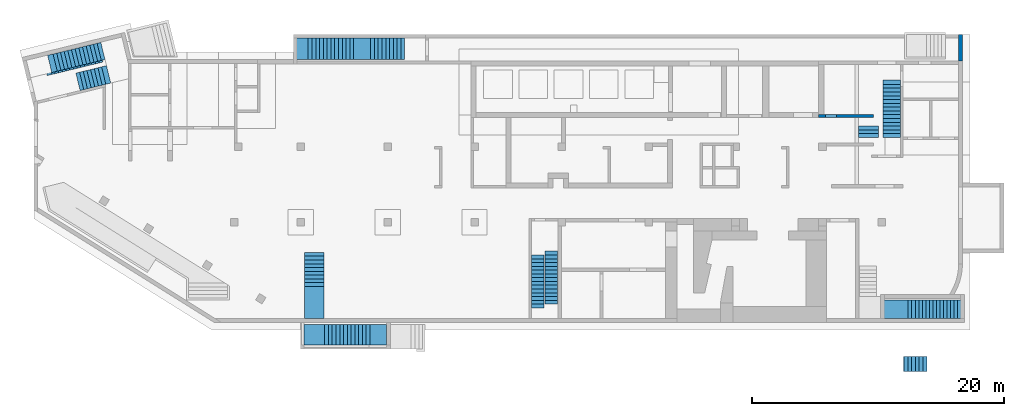
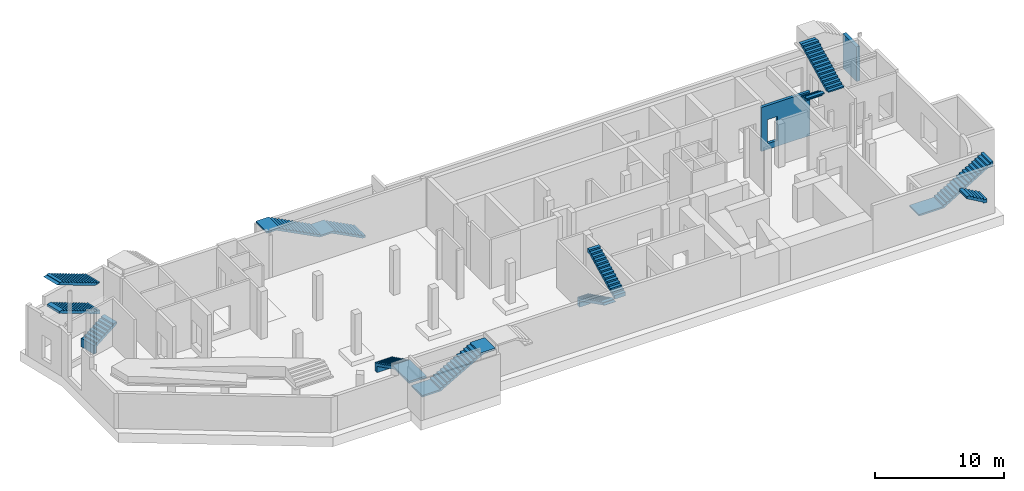
# One storey, part 4 of 9: 11 stairs, 2 walls, 2 openings.
"""IFC4 building model written with IfcOpenShell, lengths in millimetres."""

from ifc_helpers import new_model, entity, si_unit, converted_unit, derived_unit, direction, frame, origin, place, context, subcontext, project, spatial, indexed_curve, outline, extrude, polygons, material, type_object, element, save


model = new_model("IFC4")

# Units and contexts
model_context = context("Model", 3, precision=0.01, world=origin(), true_north=direction((6.12303176911189e-17, 1.0)))
plan_context = context("Plan", 3, precision=0.01, world=origin(), true_north=direction((6.12303176911189e-17, 1.0)))
body_context = subcontext(model_context, "Body", "Model", "MODEL_VIEW")
ifc_project = project(units=[si_unit("LENGTHUNIT", "METRE", prefix="MILLI"), si_unit("AREAUNIT", "SQUARE_METRE"), si_unit("VOLUMEUNIT", "CUBIC_METRE"), converted_unit("PLANEANGLEUNIT", "DEGREE", entity("IfcRatioMeasure", 0.0174532925199433), si_unit("PLANEANGLEUNIT", "RADIAN"), dimensions=[0, 0, 0, 0, 0, 0, 0]), si_unit("MASSUNIT", "GRAM", prefix="KILO"), derived_unit("MASSDENSITYUNIT", [(si_unit("MASSUNIT", "GRAM", prefix="KILO"), 1), (si_unit("LENGTHUNIT", "METRE"), -3)]), derived_unit("MOMENTOFINERTIAUNIT", [(si_unit("LENGTHUNIT", "METRE"), 4)]), si_unit("TIMEUNIT", "SECOND"), si_unit("FREQUENCYUNIT", "HERTZ"), si_unit("THERMODYNAMICTEMPERATUREUNIT", "DEGREE_CELSIUS"), derived_unit("THERMALTRANSMITTANCEUNIT", [(si_unit("MASSUNIT", "GRAM", prefix="KILO"), 1), (si_unit("THERMODYNAMICTEMPERATUREUNIT", "KELVIN"), -1), (si_unit("TIMEUNIT", "SECOND"), -3)]), derived_unit("VOLUMETRICFLOWRATEUNIT", [(si_unit("LENGTHUNIT", "METRE"), 3), (si_unit("TIMEUNIT", "SECOND"), -1)]), derived_unit("MASSFLOWRATEUNIT", [(si_unit("MASSUNIT", "GRAM", prefix="KILO"), 1), (si_unit("TIMEUNIT", "SECOND"), -1)]), derived_unit("ROTATIONALFREQUENCYUNIT", [(si_unit("TIMEUNIT", "SECOND"), -1)]), si_unit("ELECTRICCURRENTUNIT", "AMPERE"), si_unit("ELECTRICVOLTAGEUNIT", "VOLT"), si_unit("POWERUNIT", "WATT"), si_unit("FORCEUNIT", "NEWTON", prefix="KILO"), si_unit("ILLUMINANCEUNIT", "LUX"), si_unit("LUMINOUSFLUXUNIT", "LUMEN"), si_unit("LUMINOUSINTENSITYUNIT", "CANDELA"), derived_unit("USERDEFINED", [(si_unit("MASSUNIT", "GRAM", prefix="KILO"), -1), (si_unit("LENGTHUNIT", "METRE"), -2), (si_unit("TIMEUNIT", "SECOND"), 3), (si_unit("LUMINOUSFLUXUNIT", "LUMEN"), 1)]), derived_unit("LINEARVELOCITYUNIT", [(si_unit("LENGTHUNIT", "METRE"), 1), (si_unit("TIMEUNIT", "SECOND"), -1)]), si_unit("PRESSUREUNIT", "PASCAL"), derived_unit("USERDEFINED", [(si_unit("LENGTHUNIT", "METRE"), -2), (si_unit("MASSUNIT", "GRAM", prefix="KILO"), 1), (si_unit("TIMEUNIT", "SECOND"), -2)]), derived_unit("LINEARFORCEUNIT", [(si_unit("MASSUNIT", "GRAM", prefix="KILO"), 1), (si_unit("LENGTHUNIT", "METRE"), 1), (si_unit("TIMEUNIT", "SECOND"), -2), (si_unit("LENGTHUNIT", "METRE"), -1)]), derived_unit("PLANARFORCEUNIT", [(si_unit("MASSUNIT", "GRAM", prefix="KILO"), 1), (si_unit("LENGTHUNIT", "METRE"), 1), (si_unit("TIMEUNIT", "SECOND"), -2), (si_unit("LENGTHUNIT", "METRE"), -2)])], contexts=[model_context, plan_context])

# Site, building, storey
site_placement = place(None, origin())
site = spatial("IfcSite", under=ifc_project, at=site_placement, CompositionType="ELEMENT")
building_placement = place(site_placement, origin())
building = spatial("IfcBuilding", under=site, at=building_placement, CompositionType="ELEMENT")
storey_placement = place(building_placement, frame((0.0, 0.0, -4900.0)))
storey = spatial("IfcBuildingStorey", under=building, at=storey_placement, CompositionType="ELEMENT", Elevation=-4900.0)

# Wall, opening
ifc_material_1 = material()
wall_type_1 = type_object("IfcWallType", Name=":ADSK_ 25_300", PredefinedType="STANDARD")
wall_1_placement = place(storey_placement, frame((73520.0, 20500.0, 0.0), z_axis=(0.0, 0.0, 1.0), x_axis=(0.0, 1.0, 0.0)))
wall_1 = element("IfcWall", 1, at=wall_1_placement, inside=storey, type_object=wall_type_1, material=ifc_material_1, Name=":ADSK_ 25_300", ObjectType=":ADSK_ 25_300", PredefinedType="NOTDEFINED", context=body_context, shape_type="Tessellation", body=[
    polygons([(0.0, -150.000000000004, 0.0), (2100.0, -149.999999999999, 0.0), (2100.0, -149.999999999999, 3300.0), (0.000426244457389657, -150.000000000004, 3300.0), (0.0, 149.999999999997, 0.0), (0.0, 149.999999999997, 3300.0), (1800.0, 150.000000000002, 3300.0), (2100.00042624446, 150.000000000002, 3300.0), (2100.0, 150.000000000002, 0.0), (1800.0, 150.000000000002, 0.0)], [[[1, 2, 3, 4]], [[5, 6, 7, 8, 9, 10]], [[2, 1, 5, 10, 9]], [[3, 2, 9, 8]], [[4, 3, 8, 7, 6]], [[1, 4, 6, 5]]], closed=True),
])
opening_1_placement = place(wall_1_placement, origin())
element("IfcOpeningElement", 2, at=opening_1_placement, cuts=wall_1, Name=":ADSK_ 25_300", PredefinedType="OPENING", context=body_context, shape_type="SweptSolid", body=[
    extrude(outline(indexed_curve([(-1250.0, -1249.99999999902), (1250.0, -1249.99999999902), (1250.0, 1249.99999999902), (-1250.0, 1249.99999999902), (-1250.0, -1249.99999999902)], self_intersect=False)), frame((-11250.0, -250.0, 1950.0), z_axis=(0.0, 1.0, 0.0), x_axis=(1.0, 0.0, 0.0)), (0.0, 0.0, 1.0), 500.000000001948),
])

wall_type_2 = type_object("IfcWallType", Name=":ADSK_ 25_250", PredefinedType="STANDARD")
wall_2_placement = place(storey_placement, frame((66630.0, 16125.0, 0.0), z_axis=(0.0, 0.0, 1.0), x_axis=(-1.0, 0.0, 0.0)))
wall_2 = element("IfcWall", 3, at=wall_2_placement, inside=storey, type_object=wall_type_2, material=ifc_material_1, Name=":ADSK_ 25_250", ObjectType=":ADSK_ 25_250", PredefinedType="NOTDEFINED", context=body_context, shape_type="Tessellation", body=[
    polygons([(3.67825270252959e-12, -125.0, 0.0), (3960.0, -125.0, 0.0), (4359.99999999999, -125.0, 0.0), (4359.99999999999, -125.0, 4170.0), (3960.0, -125.0, 4170.0), (1500.00000000001, -125.0, 4170.0), (1200.00000000001, -125.0, 4170.0), (3.67825270252959e-12, -125.0, 4170.0), (2929.99999999999, -125.0, 2829.99999999805), (3809.99999999998, -125.000000000002, 2829.99999999804), (3809.99999999998, -125.000000000002, 550.0), (2929.99999999999, -125.0, 550.0), (4359.99999999999, 125.000000000002, 0.0), (2.95528439311811e-12, 125.0, 0.0), (2.95528439311811e-12, 125.0, 4170.0), (1200.00000000001, 125.0, 4170.0), (1500.00000000001, 125.0, 4170.0), (3959.99999999999, 125.0, 4170.0), (4359.99999999999, 125.000000000002, 4170.0), (3809.99999999998, 125.0, 2829.99999999804), (2930.0, 125.0, 2829.99999999805), (2929.99999999999, 125.0, 550.0), (3809.99999999998, 125.0, 550.0)], [[[1, 2, 3, 4, 5, 6, 7, 8], [9, 10, 11, 12]], [[13, 14, 15, 16, 17, 18, 19], [20, 21, 22, 23]], [[3, 2, 1, 14, 13]], [[8, 7, 6, 5, 4, 19, 18, 17, 16, 15]], [[1, 8, 15, 14]], [[4, 3, 13, 19]], [[9, 21, 20, 10]], [[10, 20, 23, 11]], [[11, 23, 22, 12]], [[21, 9, 12, 22]]], closed=True),
])
opening_2_placement = place(wall_2_placement, frame((66630.0, 16125.0, 0.0), z_axis=(0.0, 0.0, 1.0), x_axis=(-1.0, 0.0, 0.0)))
element("IfcOpeningElement", 4, at=opening_2_placement, cuts=wall_2, Name=":ADSK_ 25_250", PredefinedType="OPENING", context=body_context, shape_type="SweptSolid", body=[
    extrude(outline(indexed_curve([(-439.999999999995, -1139.99999999902), (440.000000000004, -1139.99999999902), (440.000000000004, 1139.99999999902), (-439.999999999995, 1139.99999999902), (-439.999999999995, -1139.99999999902)], self_intersect=False)), frame((63260.0, 16350.0, 1690.0), z_axis=(0.0, -1.0, 0.0), x_axis=(-1.0, 0.0, 0.0)), (0.0, 0.0, 1.0), 450.000000000965),
])

# Stairs
ifc_material_2 = material()
stair_type_1 = type_object("IfcStairType", Name="1: 1", PredefinedType="HALF_TURN_STAIR")
placement = place(storey_placement, origin())
element("IfcStair", 5, at=placement, inside=storey, type_object=stair_type_1, material=ifc_material_2, Name="1: 1", ObjectType="1: 1", PredefinedType="HALF_TURN_STAIR", context=body_context, shape_type="SweptSolid", body=[
    extrude(outline(indexed_curve([(884.697440245459, -649.658737997728), (1284.69744024546, -649.658737997728), (1284.69744024546, -449.658737997728), (1231.91103574541, -449.658737997728), (674.14015934545, -170.773299797745), (-915.302559754544, 623.948059752256), (-915.302559754547, 1220.34126200228), (-1215.30255975455, 1220.34126200228), (-1215.30255975455, 400.341262002277), (-915.302559754545, 400.341262002276), (-915.302559754546, 250.341262002277), (-615.302559754544, 250.341262002276), (-615.302559754546, 100.341262002276), (-315.302559754542, 100.341262002275), (-315.302559754543, -49.6587379977246), (-15.3025597545405, -49.6587379977254), (-15.3025597545419, -199.658737997725), (284.69744024546, -199.658737997726), (284.697440245459, -349.658737997726), (584.697440245461, -349.658737997727), (584.69744024546, -499.658737997727), (884.69744024546, -499.658737997728), (884.697440245459, -649.658737997728)], self_intersect=False)), frame((4851.81, 18434.3, 1220.34), z_axis=(-0.236826092990336, 0.971552058141473, 0.0), x_axis=(0.971552058141473, 0.236826092990336, 0.0)), (0.0, 0.0, 1.0), 1419.99999999999),
])
stair_type_2 = type_object("IfcStairType", Name="2: 2", PredefinedType="HALF_TURN_STAIR")
element("IfcStair", 6, at=placement, inside=storey, type_object=stair_type_2, material=ifc_material_2, Name="2: 2", ObjectType="2: 2", PredefinedType="HALF_TURN_STAIR", context=body_context, shape_type="SweptSolid", body=[
    extrude(outline(indexed_curve([(907.575757575757, -2048.08978365272), (1257.57575757576, -2048.08978365272), (1257.57575757576, -2000.87618815276), (-842.424242424243, 2199.12381184728), (-842.424242424243, 2298.17805111697), (-1042.42424242424, 2298.17805111697), (-1042.42424242424, 1851.91021634732), (-892.424242424243, 1851.91021634732), (-892.424242424243, 1551.91021634731), (-742.424242424243, 1551.91021634731), (-742.424242424243, 1251.91021634731), (-592.424242424243, 1251.91021634731), (-592.424242424243, 951.910216347304), (-442.424242424243, 951.910216347304), (-442.424242424243, 651.910216347299), (-292.424242424243, 651.910216347299), (-292.424242424243, 351.910216347297), (-142.424242424243, 351.910216347297), (-142.424242424243, 51.9102163472945), (7.57575757575671, 51.9102163472945), (7.57575757575671, -248.08978365271), (157.575757575757, -248.08978365271), (157.575757575757, -548.089783652713), (307.575757575757, -548.089783652713), (307.575757575757, -848.089783652714), (457.575757575757, -848.089783652714), (457.575757575757, -1148.08978365272), (607.575757575757, -1148.08978365272), (607.575757575757, -1448.08978365272), (757.575757575757, -1448.08978365272), (757.575757575757, -1748.08978365272), (907.575757575757, -1748.08978365272), (907.575757575757, -2048.08978365272)], self_intersect=False)), frame((3655.43, 20118.89, 2927.58), z_axis=(-0.236826092990328, 0.971552058141475, 0.0), x_axis=(0.0, 0.0, -1.0)), (0.0, 0.0, 1.0), 1400.0),
])
stair_type_3 = type_object("IfcStairType", Name="4: 4", PredefinedType="HALF_TURN_STAIR")
element("IfcStair", 7, at=placement, inside=storey, type_object=stair_type_3, material=ifc_material_2, Name="4: 4", ObjectType="4: 4", PredefinedType="HALF_TURN_STAIR", context=body_context, shape_type="SweptSolid", body=[
    extrude(outline(indexed_curve([(982.941176470589, -2214.83609385294), (1332.94117647059, -2214.83609385294), (1332.94117647059, -2167.62249835299), (-597.058823529415, 1692.37750164703), (-597.058823529415, 1960.16390614706), (-847.058823529415, 1960.16390614706), (-847.058823529415, 1985.16390614706), (-967.058823529411, 1985.16390614706), (-967.058823529411, 1685.16390614706), (-817.058823529411, 1685.16390614706), (-817.058823529411, 1385.16390614706), (-667.058823529411, 1385.16390614706), (-667.058823529411, 1085.16390614706), (-517.058823529411, 1085.16390614706), (-517.058823529411, 785.16390614706), (-367.058823529411, 785.163906147061), (-367.058823529411, 485.16390614706), (-217.058823529411, 485.16390614706), (-217.058823529411, 185.16390614706), (-67.0588235294113, 185.16390614706), (-67.0588235294114, -114.836093852941), (82.9411764705886, -114.836093852941), (82.9411764705886, -414.836093852941), (232.941176470589, -414.836093852941), (232.941176470589, -714.836093852942), (382.941176470589, -714.836093852942), (382.941176470589, -1014.83609385294), (532.941176470589, -1014.83609385294), (532.941176470589, -1314.83609385294), (682.941176470589, -1314.83609385294), (682.941176470589, -1614.83609385294), (832.941176470589, -1614.83609385294), (832.941176470589, -1914.83609385294), (982.941176470589, -1914.83609385294), (982.941176470589, -2214.83609385294)], self_intersect=False)), frame((40550.0, 3414.84, 3902.94), z_axis=(1.0, 0.0, 0.0), x_axis=(0.0, 0.0, -1.0)), (0.0, 0.0, 1.0), 999.999999999998),
    extrude(outline(indexed_curve([(-1987.5, -836.337075140623), (-1987.5, -1656.33707514062), (-1687.5, -1656.33707514062), (-1687.5, -1059.9438728906), (2212.5, 890.056127109391), (2212.5, 913.662924859368), (1912.5, 913.662924859367), (1912.5, 963.66292485937), (1612.5, 963.662924859371), (1612.5, 813.662924859371), (1312.5, 813.662924859371), (1312.5, 663.662924859371), (1012.5, 663.662924859372), (1012.5, 513.662924859372), (712.500000000001, 513.662924859373), (712.5, 363.662924859372), (412.5, 363.662924859373), (412.5, 213.662924859373), (112.5, 213.662924859374), (112.499999999999, 63.6629248593734), (-187.500000000001, 63.6629248593739), (-187.500000000001, -86.3370751406256), (-487.500000000001, -86.337075140625), (-487.500000000001, -236.337075140626), (-787.500000000001, -236.337075140625), (-787.500000000001, -386.337075140625), (-1087.5, -386.337075140624), (-1087.5, -536.337075140625), (-1387.5, -536.337075140624), (-1387.5, -686.337075140623), (-1687.5, -686.337075140623), (-1687.5, -836.337075140623), (-1987.5, -836.337075140623)], self_intersect=False)), frame((39490.0, 3112.5, 1656.34), z_axis=(-1.0, 0.0, 0.0), x_axis=(0.0, -1.0, 0.0)), (0.0, 0.0, -1.0), 999.999999999998),
])
stair_type_4 = type_object("IfcStairType", Name="5: 5", PredefinedType="HALF_TURN_STAIR")
element("IfcStair", 8, at=placement, inside=storey, type_object=stair_type_4, material=ifc_material_2, Name="5: 5", ObjectType="5: 5", PredefinedType="HALF_TURN_STAIR", context=body_context, shape_type="SweptSolid", body=[
    extrude(outline(indexed_curve([(1054.11145618, -792.544271909995), (3604.11145618, -792.544271909995), (3604.11145618, -592.544271909995), (1401.32505167996, -592.544271909995), (-1345.88854382, 781.062525839977), (-1345.88854382, 1377.45572808999), (-1645.88854382, 1377.45572808999), (-1645.88854382, 557.455728089999), (-1345.88854382, 557.455728089999), (-1345.88854382, 407.455728089999), (-1045.88854382, 407.45572809), (-1045.88854382, 257.45572809), (-745.888543819999, 257.45572809), (-745.888543819999, 107.45572809), (-445.888543819999, 107.455728090001), (-445.888543819999, -42.5442719099993), (-145.888543819999, -42.5442719099988), (-145.888543819999, -192.544271909999), (154.111456180001, -192.544271909998), (154.111456180001, -342.544271909998), (454.111456180001, -342.544271909998), (454.111456180001, -492.544271909998), (754.111456180001, -492.544271909997), (754.111456180001, -642.544271909997), (1054.11145618, -642.544271909997), (1054.11145618, -792.544271909995)], self_intersect=False)), frame((21470.0, 3654.11, 1377.46), z_axis=(1.0, 0.0, 0.0), x_axis=(0.0, -1.0, 0.0)), (0.0, 0.0, 1.0), 1550.0),
])
stair_type_5 = type_object("IfcStairType", Name="7: 7", PredefinedType="HALF_TURN_STAIR")
element("IfcStair", 9, at=placement, inside=storey, type_object=stair_type_5, material=ifc_material_2, Name="7: 7", ObjectType="7: 7", PredefinedType="HALF_TURN_STAIR", context=body_context, shape_type="SweptSolid", body=[
    extrude(outline(indexed_curve([(-1086.25, -1792.4716246135), (-916.250000000001, -1792.4716246135), (-916.250000000001, -1492.4716246135), (-746.25, -1492.4716246135), (-746.25, -1192.4716246135), (-576.25, -1192.4716246135), (-576.25, -892.471624613499), (-406.25, -892.471624613499), (-406.25, -592.471624613498), (-236.249999999999, -592.471624613498), (-236.249999999999, -292.471624613497), (-66.249999999999, -292.471624613497), (-66.249999999999, 7.52837538650388), (103.750000000001, 7.52837538650388), (103.750000000001, 307.528375386505), (273.750000000002, 307.528375386505), (273.750000000002, 607.528375386506), (443.750000000002, 607.528375386506), (443.750000000002, 907.528375386507), (613.750000000002, 907.528375386507), (613.750000000002, 1207.52837538651), (783.750000000003, 1207.52837538651), (783.750000000003, 1507.52837538651), (953.750000000003, 1507.52837538651), (953.750000000003, 1807.52837538651), (1123.75, 1807.52837538651), (1123.75, 3127.52837538649), (973.750000000003, 3127.52837538649), (973.75, 2147.07436920239), (-1236.25, -1752.92563079762), (-1236.25000000001, -3422.4716246135), (-1086.25000000001, -3422.4716246135), (-1086.25, -1792.4716246135)], self_intersect=False)), frame((24862.47, -2050.0, 3196.25), z_axis=(0.0, 1.0, 0.0), x_axis=(0.0, 0.0, 1.0)), (0.0, 0.0, 1.0), 1650.0),
])
stair_type_6 = type_object("IfcStairType", Name="9: 9", PredefinedType="HALF_TURN_STAIR")
element("IfcStair", 10, at=placement, inside=storey, type_object=stair_type_6, material=ifc_material_2, Name="9: 9", ObjectType="9: 9", PredefinedType="HALF_TURN_STAIR", context=body_context, shape_type="SweptSolid", body=[
    extrude(outline(indexed_curve([(-1327.89473684208, -1993.77245141249), (-1157.89473684208, -1993.77245141249), (-1157.89473684208, -1713.7724514125), (-987.894736842088, -1713.7724514125), (-987.894736842088, -1433.7724514125), (-817.89473684209, -1433.7724514125), (-817.89473684209, -1153.7724514125), (-647.894736842093, -1153.7724514125), (-647.894736842093, -873.772451412505), (-477.894736842096, -873.772451412505), (-477.894736842096, -593.772451412508), (-307.894736842099, -593.772451412508), (-307.894736842099, -313.772451412511), (-137.894736842102, -313.772451412511), (-137.894736842102, -33.7724514125137), (32.105263157895, -33.7724514125137), (32.105263157895, 246.227548587483), (202.105263157892, 246.227548587483), (202.105263157892, 526.22754858748), (372.105263157889, 526.22754858748), (372.105263157889, 806.227548587477), (542.105263157886, 806.227548587477), (542.105263157886, 1086.22754858747), (712.105263157884, 1086.22754858747), (712.105263157884, 1366.22754858747), (882.105263157881, 1366.22754858747), (882.105263157881, 1646.22754858747), (1052.10526315788, 1646.22754858747), (1052.10526315788, 1926.22754858747), (1222.10526315788, 1926.22754858747), (1222.10526315788, 2206.22754858746), (1392.10526315787, 2206.22754858746), (1392.10526315787, 2461.22754858751), (932.105263157873, 2461.22754858751), (932.105263157871, 2017.6100077785), (-1477.89473684209, -1951.80175692734), (-1477.89473684209, -4193.77245141249), (-1327.89473684209, -4193.77245141249), (-1327.89473684208, -1993.77245141249)], self_intersect=False)), frame((71363.77, 50.0, 3297.89), z_axis=(0.0, 1.0, 0.0), x_axis=(0.0, 0.0, 1.0)), (0.0, 0.0, 1.0), 1495.00000000001),
])
stair_type_7 = type_object("IfcStairType", Name="10: 10", PredefinedType="HALF_TURN_STAIR")
element("IfcStair", 11, at=placement, inside=storey, type_object=stair_type_7, material=ifc_material_2, Name="10: 10", ObjectType="10: 10", PredefinedType="HALF_TURN_STAIR", context=body_context, shape_type="SweptSolid", body=[
    extrude(outline(indexed_curve([(-1736.15384615384, -3570.97946302001), (-1736.15384615384, -4750.97946302001), (-1586.15384615384, -4750.97946302001), (-1586.15384615384, -3907.43999214716), (428.846153846153, -7.4399921471611), (428.84615384615, 1042.56000785285), (1873.84615384615, 3839.33420140125), (1873.84615384615, 4079.02053698002), (1673.84615384615, 4079.02053698002), (1673.84615384615, 3779.02053698002), (1518.84615384615, 3779.02053698002), (1518.84615384615, 3479.02053698001), (1363.84615384615, 3479.02053698001), (1363.84615384615, 3179.02053698001), (1208.84615384615, 3179.02053698001), (1208.84615384615, 2879.02053698001), (1053.84615384615, 2879.02053698001), (1053.84615384615, 2579.02053698001), (898.846153846149, 2579.02053698001), (898.846153846149, 2279.02053698001), (743.846153846149, 2279.02053698001), (743.846153846149, 1979.02053698001), (588.846153846149, 1979.02053698001), (588.846153846149, 1679.02053698001), (433.846153846149, 1679.02053698001), (433.846153846149, 1379.02053698001), (278.846153846149, 1379.02053698001), (278.846153846153, 29.0205369800062), (123.846153846159, 29.0205369800062), (123.846153846159, -270.979463019995), (-31.1538461538414, -270.979463019995), (-31.1538461538414, -570.979463019996), (-186.153846153841, -570.979463019996), (-186.153846153841, -870.979463019997), (-341.153846153841, -870.979463019997), (-341.153846153841, -1170.97946302), (-496.153846153841, -1170.97946302), (-496.153846153841, -1470.97946302), (-651.153846153841, -1470.97946302), (-651.153846153841, -1770.97946302), (-806.153846153841, -1770.97946302), (-806.153846153841, -2070.97946302), (-961.153846153841, -2070.97946302), (-961.153846153841, -2370.97946302), (-1116.15384615384, -2370.97946302), (-1116.15384615384, -2670.97946302), (-1271.15384615384, -2670.97946302), (-1271.15384615384, -2970.97946302), (-1426.15384615384, -2970.97946302), (-1426.15384615384, -3270.97946302001), (-1581.15384615384, -3270.97946302001), (-1581.15384615384, -3570.97946302001), (-1736.15384615384, -3570.97946302001)], self_intersect=False)), frame((25340.98, 20600.0, 2448.85), z_axis=(0.0, -1.0, 0.0), x_axis=(0.0, 0.0, -1.0)), (0.0, 0.0, -1.0), 1699.99999999999),
])
stair_type_8 = type_object("IfcStairType", Name="14: 14", PredefinedType="HALF_TURN_STAIR")
element("IfcStair", 12, at=placement, inside=storey, type_object=stair_type_8, material=ifc_material_2, Name="14: 14", ObjectType="14: 14", PredefinedType="HALF_TURN_STAIR", context=body_context, shape_type="SweptSolid", body=[
    extrude(outline(indexed_curve([(-784.999999999995, -150.000000000002), (784.999999999995, -150.000000000002), (784.999999999995, 149.999999999999), (-784.999999999995, 149.999999999999), (-784.999999999995, -150.000000000002)], self_intersect=False)), frame((66215.0, 14580.0, 4750.0), z_axis=(0.0, 0.0, 1.0), x_axis=(-1.0, 0.0, 0.0)), (0.0, 0.0, 1.0), 120.000000000003),
    extrude(outline(indexed_curve([(-150.000000000001, -299.999999999999), (-6.76791955811495e-13, -299.999999999999), (2.70716782324598e-13, 0.0), (150.0, 0.0), (150.000000000001, 300.000000000001), (-150.000000000001, 300.000000000001), (-150.000000000001, -299.999999999999)], self_intersect=False)), frame((65430.0, 15030.0, 4570.0), z_axis=(1.0, 0.0, 0.0), x_axis=(0.0, 0.0, 1.0)), (0.0, 0.0, 1.0), 1570.00000000001),
])
stair_type_9 = type_object("IfcStairType", Name="15: 15", PredefinedType="HALF_TURN_STAIR")
element("IfcStair", 13, at=placement, inside=storey, type_object=stair_type_9, material=ifc_material_2, Name="15: 15", ObjectType="15: 15", PredefinedType="HALF_TURN_STAIR", context=body_context, shape_type="SweptSolid", body=[
    extrude(outline(indexed_curve([(897.124385988235, -2015.78400925296), (1017.12438598824, -2015.78400925296), (1017.12438598824, -1715.78400925295), (1076.00982418822, -1715.78400925295), (1076.00982418822, -1626.34129015296), (-1002.87561401176, 2531.42958624701), (-1002.87561401176, 2184.21599074706), (-1052.87561401176, 2184.21599074706), (-1052.87561401176, 1884.21599074706), (-902.875614011764, 1884.21599074706), (-902.875614011764, 1584.21599074706), (-752.875614011764, 1584.21599074706), (-752.875614011764, 1284.21599074706), (-602.875614011764, 1284.21599074706), (-602.875614011764, 984.215990747055), (-452.875614011764, 984.215990747055), (-452.875614011764, 684.215990747054), (-302.875614011764, 684.215990747054), (-302.875614011764, 384.215990747053), (-152.875614011764, 384.215990747053), (-152.875614011764, 84.2159907470516), (-2.8756140117639, 84.2159907470516), (-2.8756140117639, -215.784009252949), (147.124385988236, -215.784009252949), (147.124385988236, -515.784009252951), (297.124385988236, -515.784009252951), (297.124385988236, -815.784009252952), (447.124385988236, -815.784009252952), (447.124385988236, -1115.78400925295), (597.124385988236, -1115.78400925295), (597.124385988236, -1415.78400925295), (747.124385988236, -1415.78400925295), (747.124385988236, -1715.78400925296), (897.124385988236, -1715.78400925296), (897.124385988235, -2015.78400925296)], self_intersect=False)), frame((67360.0, 16445.78, 5767.12), z_axis=(1.0, 0.0, 0.0), x_axis=(0.0, 0.0, -1.0)), (0.0, 0.0, 1.0), 1390.0),
])
stair_type_10 = type_object("IfcStairType", Name="3: 3", PredefinedType="HALF_TURN_STAIR")
element("IfcStair", 14, at=placement, inside=storey, type_object=stair_type_10, material=ifc_material_2, Name="3: 3", ObjectType="3: 3", PredefinedType="HALF_TURN_STAIR", context=body_context, shape_type="SweptSolid", body=[
    extrude(outline(indexed_curve([(964.374999999993, -2126.70084971877), (1084.37499999999, -2126.70084971877), (1084.37499999999, -1619.48725421881), (-935.625000000008, 2420.51274578127), (-935.625000000009, 2073.29915028128), (-985.624999999992, 2073.29915028128), (-985.624999999993, 1773.29915028128), (-835.624999999993, 1773.29915028128), (-835.624999999994, 1473.29915028127), (-685.624999999993, 1473.29915028127), (-685.624999999994, 1173.29915028127), (-535.624999999994, 1173.29915028127), (-535.624999999995, 873.299150281263), (-385.624999999995, 873.299150281262), (-385.624999999996, 573.299150281258), (-235.624999999996, 573.299150281257), (-235.624999999997, 273.299150281254), (-85.6249999999973, 273.299150281252), (-85.6249999999983, -26.7008497187483), (64.3750000000013, -26.7008497187509), (64.3750000000004, -326.700849718753), (214.375, -326.700849718754), (214.374999999999, -626.700849718755), (364.374999999999, -626.700849718756), (364.374999999998, -926.700849718759), (514.374999999998, -926.70084971876), (514.374999999997, -1226.70084971876), (664.374999999996, -1226.70084971876), (664.374999999995, -1526.70084971877), (814.374999999995, -1526.70084971877), (814.374999999994, -1826.70084971877), (964.374999999994, -1826.70084971877), (964.374999999993, -2126.70084971877)], self_intersect=False)), frame((3414.18, 19905.69, 5834.37), z_axis=(-0.236826092990336, 0.971552058141473, 0.0), x_axis=(0.0, 0.0, -1.0)), (0.0, 0.0, 1.0), 1550.00000000006),
])
stair_type_11 = type_object("IfcStairType", Name="42: 42", PredefinedType="HALF_TURN_STAIR")
element("IfcStair", 15, at=placement, inside=storey, type_object=stair_type_11, material=ifc_material_2, Name="42: 42", ObjectType="42: 42", PredefinedType="HALF_TURN_STAIR", context=body_context, shape_type="SweptSolid", body=[
    extrude(outline(indexed_curve([(-524.698776195736, -614.54541224973), (-524.698776195736, -914.545412249731), (-324.698776195737, -914.545412249731), (-324.698776195737, -967.273404004243), (555.18041913181, 585.454587750266), (645.301223804264, 585.454587750266), (645.301223804263, 885.454587750276), (325.301223804259, 885.454587750276), (325.30122380426, 585.454587750275), (155.30122380426, 585.454587750275), (155.301223804261, 285.454587750274), (-14.6987761957394, 285.454587750274), (-14.6987761957383, -14.5454122497275), (-184.698776195738, -14.5454122497275), (-184.698776195737, -314.545412249729), (-354.698776195737, -314.545412249729), (-354.698776195736, -614.54541224973), (-524.698776195736, -614.54541224973)], self_intersect=False)), frame((69959.67, -4155.0, 5065.3), z_axis=(0.0, -1.0, 0.0), x_axis=(0.0, 0.0, -1.0)), (0.0, 0.0, -1.0), 1200.0),
])

save(model, "model.ifc")
